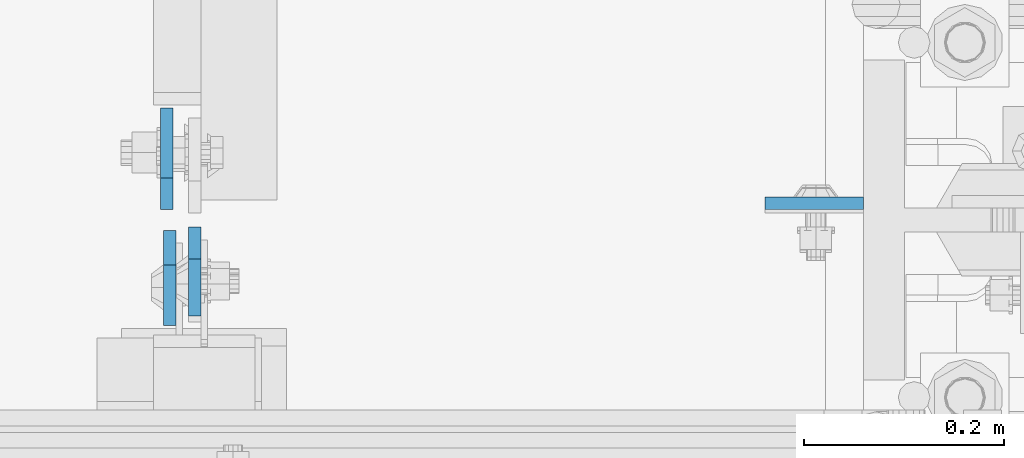
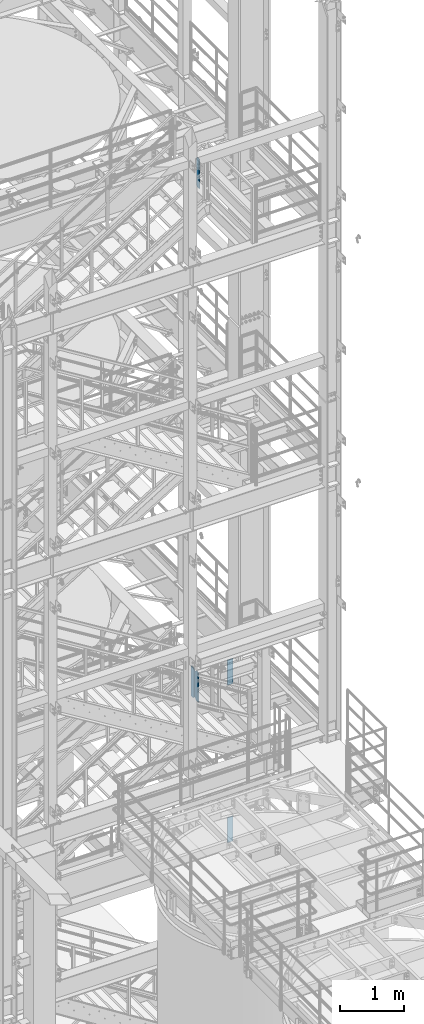
# One storey, part 1506 of 1876: 5 plates, 3 elements without a shape of their own.
"""IFC2X3 building model written with IfcOpenShell, lengths in millimetres."""

from ifc_helpers import new_model, si_unit, frame, origin_with_axes, place, context, subcontext, project, spatial, faceted_brep, material, type_object, element, aggregate, save


model = new_model("IFC2X3")

# Units and contexts
model_context = context("Model", 3, precision=1e-05, world=origin_with_axes())
body_context = subcontext(model_context, "Body", "Model", "MODEL_VIEW")
ifc_project = project(units=[si_unit("LENGTHUNIT", "METRE", prefix="MILLI"), si_unit("AREAUNIT", "SQUARE_METRE"), si_unit("VOLUMEUNIT", "CUBIC_METRE"), si_unit("MASSUNIT", "GRAM", prefix="KILO"), si_unit("TIMEUNIT", "SECOND"), si_unit("PLANEANGLEUNIT", "RADIAN"), si_unit("SOLIDANGLEUNIT", "STERADIAN"), si_unit("THERMODYNAMICTEMPERATUREUNIT", "DEGREE_CELSIUS"), si_unit("LUMINOUSINTENSITYUNIT", "LUMEN")], contexts=[model_context])

# Site, building, storey
site_placement = place(None, origin_with_axes())
site = spatial("IfcSite", under=ifc_project, at=site_placement, CompositionType="ELEMENT")
building_placement = place(site_placement, origin_with_axes())
building = spatial("IfcBuilding", under=site, at=building_placement, Name="Undefined", CompositionType="ELEMENT")
storey_placement = place(building_placement, origin_with_axes())
storey = spatial("IfcBuildingStorey", under=building, at=storey_placement, Name="Undefined", CompositionType="ELEMENT", Elevation=0.0)

# Assembly, plates
assembly_1_placement = place(storey_placement, origin_with_axes())
assembly_1 = element("IfcElementAssembly", 1, at=assembly_1_placement, inside=storey, Name="COLUMN", AssemblyPlace="NOTDEFINED", PredefinedType="RIGID_FRAME")
ifc_material_1 = material(Name="STEEL/A572-50")
plate_type_1 = type_object("IfcPlateType", PredefinedType="NOTDEFINED")
plate_1_placement = place(assembly_1_placement, frame((7327.9, -4555.33200016022, 8070.85), z_axis=(-1.0, 0.0, 0.0), x_axis=(0.0, 0.0, -1.0)))
plate_1 = element("IfcPlate", 2, at=plate_1_placement, type_object=plate_type_1, material=ifc_material_1, Name="PLATE", context=body_context, shape_type="Brep", body=[
    faceted_brep([(0.0, -6.35000000000036, 0.0), (0.0, -6.34999999999991, 98.4250030517578), (0.0, 6.34999999999991, 98.4250030517578), (0.0, 6.35000000000036, 0.0), (482.600006103516, -6.35000000000036, 98.4250030517578), (482.600006103516, 6.35000000000036, 98.4250030517578), (482.600006103516, -6.35000000000036, 0.0), (482.600006103516, 6.35000000000036, 0.0)], [[[0, 1, 2, 3]], [[1, 4, 5, 2]], [[4, 6, 7, 5]], [[6, 0, 3, 7]], [[5, 7, 3, 2]], [[6, 4, 1, 0]]]),
])
plate_2_placement = place(assembly_1_placement, frame((7327.9, -4555.33200016022, 5048.25), z_axis=(-1.0, 0.0, 0.0), x_axis=(0.0, 0.0, -1.0)))
plate_2 = element("IfcPlate", 3, at=plate_2_placement, type_object=plate_type_1, material=ifc_material_1, Name="PLATE", context=body_context, shape_type="Brep", body=[
    faceted_brep([(0.0, -6.35000000000036, 0.0), (0.0, -6.34999999999991, 98.4250030517578), (0.0, 6.34999999999991, 98.4250030517578), (0.0, 6.35000000000036, 0.0), (482.600006103516, -6.35000000000036, 98.4250030517578), (482.600006103516, 6.35000000000036, 98.4250030517578), (482.600006103516, -6.35000000000036, 0.0), (482.600006103516, 6.35000000000036, 0.0)], [[[0, 1, 2, 3]], [[1, 4, 5, 2]], [[4, 6, 7, 5]], [[6, 0, 3, 7]], [[5, 7, 3, 2]], [[6, 4, 1, 0]]]),
])
aggregate(assembly_1, [plate_1, plate_2])

# Assembly, plate
assembly_2_placement = place(storey_placement, origin_with_axes())
assembly_2 = element("IfcElementAssembly", 4, at=assembly_2_placement, inside=storey, Name="BEAM", AssemblyPlace="NOTDEFINED", PredefinedType="RIGID_FRAME")
ifc_material_2 = material(Name="STEEL/A36")
plate_type_2 = type_object("IfcPlateType", PredefinedType="NOTDEFINED")
plate_3_placement = place(assembly_2_placement, frame((6657.97499990463, -4579.14375, 17386.3), z_axis=(0.0, 0.0, 1.0), x_axis=(0.0, -1.0, 0.0)))
plate_3 = element("IfcPlate", 5, at=plate_3_placement, type_object=plate_type_2, material=ifc_material_2, Name="PLATE", context=body_context, shape_type="Brep", body=[
    faceted_brep([(0.0, -6.34999999999991, 31.75), (0.0, -6.34999999999991, 539.75), (0.0, 6.34999999999991, 539.75), (0.0, 6.34999999999991, 31.75), (31.75, -6.34999999999991, 571.5), (31.75, 6.34999999999991, 571.5), (88.9000015258789, -6.34999999999991, 571.5), (88.9000015258789, 6.34999999999991, 571.5), (88.9000015258789, -6.34999999999991, 0.0), (88.9000015258789, 6.34999999999991, 0.0), (31.75, -6.34999999999991, 0.0), (31.75, 6.34999999999991, 0.0)], [[[0, 1, 2, 3]], [[1, 4, 5, 2]], [[4, 6, 7, 5]], [[6, 8, 9, 7]], [[8, 10, 11, 9]], [[10, 0, 3, 11]], [[5, 7, 9, 11, 3, 2]], [[10, 8, 6, 4, 1, 0]]]),
])
aggregate(assembly_2, [plate_3])

# Assembly, plates
assembly_3_placement = place(storey_placement, origin_with_axes())
assembly_3 = element("IfcElementAssembly", 6, at=assembly_3_placement, inside=storey, Name="BEAM", AssemblyPlace="NOTDEFINED", PredefinedType="RIGID_FRAME")
plate_type_3 = type_object("IfcPlateType", PredefinedType="NOTDEFINED")
plate_4_placement = place(assembly_3_placement, frame((6632.97187490463, -4582.31875, 7543.8), z_axis=(0.0, 0.0, 1.0), x_axis=(0.0, -1.0, 0.0)))
plate_4 = element("IfcPlate", 7, at=plate_4_placement, type_object=plate_type_3, material=ifc_material_2, Name="PLATE", context=body_context, shape_type="Brep", body=[
    faceted_brep([(0.0, -6.34999999999991, 34.9249992370605), (0.0, -6.35000000000036, 538.162475585938), (0.0, 6.35000000000036, 538.162475585938), (0.0, 6.34999999999991, 34.9249992370605), (34.9249992370605, -6.34999999999991, 573.087524414062), (34.9249992370605, 6.34999999999991, 573.087524414062), (95.25, -6.34999999999991, 573.087524414062), (95.25, 6.34999999999991, 573.087524414062), (95.25, -6.35000000000036, 0.0), (95.25, 6.35000000000036, 0.0), (34.9249992370605, -6.34999999999991, 0.0), (34.9249992370605, 6.34999999999991, 0.0)], [[[0, 1, 2, 3]], [[1, 4, 5, 2]], [[4, 6, 7, 5]], [[6, 8, 9, 7]], [[8, 10, 11, 9]], [[10, 0, 3, 11]], [[5, 7, 9, 11, 3, 2]], [[10, 8, 6, 4, 1, 0]]]),
])
plate_type_4 = type_object("IfcPlateType", PredefinedType="NOTDEFINED")
plate_5_placement = place(assembly_3_placement, frame((6630.19374988075, -4561.68125, 7543.8), z_axis=(0.0, 0.0, 1.0), x_axis=(0.0, 1.0, 0.0)))
plate_5 = element("IfcPlate", 8, at=plate_5_placement, type_object=plate_type_4, material=ifc_material_2, Name="PLATE", context=body_context, shape_type="Brep", body=[
    faceted_brep([(0.0, -6.34999999999991, 31.75), (0.0, -6.35000000000036, 541.337524414062), (0.0, 6.35000000000036, 541.337524414062), (0.0, 6.34999999999991, 31.75), (31.75, -6.35000000000036, 573.087524414062), (31.75, 6.35000000000036, 573.087524414062), (101.599998474121, -6.35000000000036, 573.087524414062), (101.599998474121, 6.35000000000036, 573.087524414062), (101.599998474121, -6.35000000000036, 0.0), (101.599998474121, 6.35000000000036, 0.0), (31.75, -6.34999999999991, 0.0), (31.75, 6.34999999999991, 0.0)], [[[0, 1, 2, 3]], [[1, 4, 5, 2]], [[4, 6, 7, 5]], [[6, 8, 9, 7]], [[8, 10, 11, 9]], [[10, 0, 3, 11]], [[5, 7, 9, 11, 3, 2]], [[10, 8, 6, 4, 1, 0]]]),
])
aggregate(assembly_3, [plate_4, plate_5])

save(model, "model.ifc")
